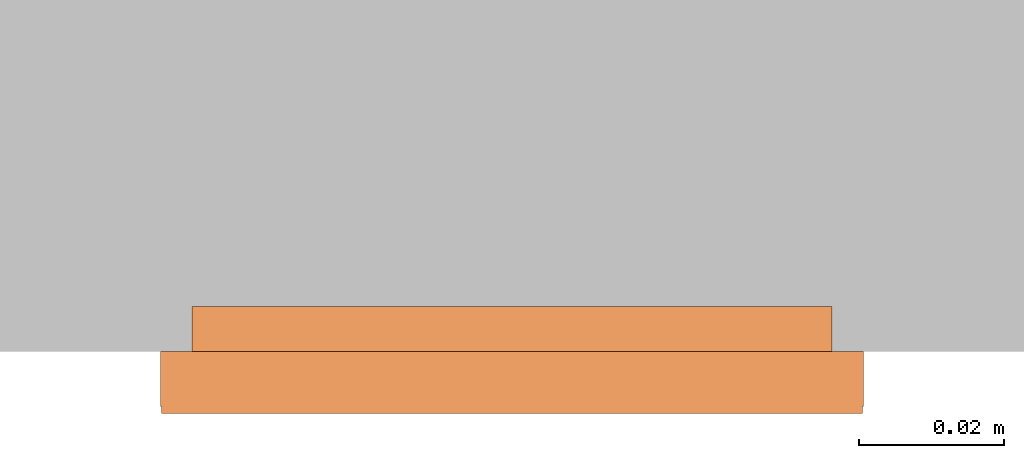
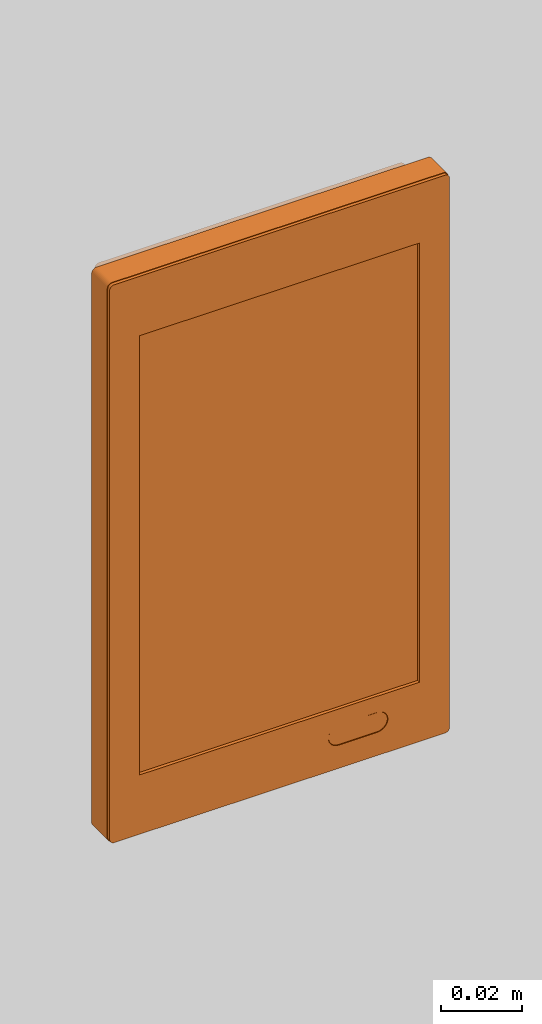
# One storey, part 2 of 2: 1 proxy.
"""IFC2X3 building model written with IfcOpenShell, lengths in metres."""

from ifc_helpers import new_model, entity, si_unit, converted_unit, derived_unit, direction, frame, frame_2d, origin, place, context, subcontext, project, spatial, polyline, circle_curve, parameter, trimmed, segment, composite_curve, outline, extrude, source, transform, mapped, material, material_list, type_object, type_shapes, element, save


model = new_model("IFC2X3")

# Units and contexts
model_context = context("Model", 3, precision=1e-05, world=origin(), true_north=direction((6.12303176911189e-17, 1.0)))
body_context = subcontext(model_context, "Body", "Model", "MODEL_VIEW")
ifc_project = project(units=[si_unit("LENGTHUNIT", "METRE"), si_unit("AREAUNIT", "SQUARE_METRE"), si_unit("VOLUMEUNIT", "CUBIC_METRE"), converted_unit("PLANEANGLEUNIT", "DEGREE", entity("IfcRatioMeasure", 0.0174532925199433), si_unit("PLANEANGLEUNIT", "RADIAN"), dimensions=[0, 0, 0, 0, 0, 0, 0]), si_unit("MASSUNIT", "GRAM", prefix="KILO"), si_unit("TIMEUNIT", "SECOND"), si_unit("FREQUENCYUNIT", "HERTZ"), si_unit("THERMODYNAMICTEMPERATUREUNIT", "DEGREE_CELSIUS"), derived_unit("THERMALTRANSMITTANCEUNIT", [(si_unit("MASSUNIT", "GRAM", prefix="KILO"), 1), (si_unit("THERMODYNAMICTEMPERATUREUNIT", "KELVIN"), -1), (si_unit("TIMEUNIT", "SECOND"), -3)]), derived_unit("VOLUMETRICFLOWRATEUNIT", [(si_unit("LENGTHUNIT", "METRE"), 3), (si_unit("TIMEUNIT", "SECOND"), -1)]), si_unit("ELECTRICCURRENTUNIT", "AMPERE"), si_unit("ELECTRICVOLTAGEUNIT", "VOLT"), si_unit("POWERUNIT", "WATT"), si_unit("FORCEUNIT", "NEWTON", prefix="KILO"), si_unit("ILLUMINANCEUNIT", "LUX"), si_unit("LUMINOUSFLUXUNIT", "LUMEN"), si_unit("LUMINOUSINTENSITYUNIT", "CANDELA"), derived_unit("USERDEFINED", [(si_unit("MASSUNIT", "GRAM", prefix="KILO"), -1), (si_unit("LENGTHUNIT", "METRE"), -2), (si_unit("TIMEUNIT", "SECOND"), 3), (si_unit("LUMINOUSFLUXUNIT", "LUMEN"), 1)]), derived_unit("LINEARVELOCITYUNIT", [(si_unit("LENGTHUNIT", "METRE"), 1), (si_unit("TIMEUNIT", "SECOND"), -1)]), si_unit("PRESSUREUNIT", "PASCAL"), derived_unit("USERDEFINED", [(si_unit("LENGTHUNIT", "METRE"), -2), (si_unit("MASSUNIT", "GRAM", prefix="KILO"), 1), (si_unit("TIMEUNIT", "SECOND"), -2)])], contexts=[model_context])

# Site, building, storey
site_placement = place(None, origin())
site = spatial("IfcSite", under=ifc_project, at=site_placement, CompositionType="ELEMENT")
building_placement = place(site_placement, origin())
building = spatial("IfcBuilding", under=site, at=building_placement, CompositionType="ELEMENT")
storey_placement = place(building_placement, origin())
storey = spatial("IfcBuildingStorey", under=building, at=storey_placement, Name="Ebene 0", CompositionType="ELEMENT", Elevation=0.0)

# Proxy
ifc_material_1 = material(Name="Black")
ifc_material_2 = material(Name="White")
ifc_material_list_1 = material_list([ifc_material_1, ifc_material_2])
ifc_material_list_2 = material_list([ifc_material_1, ifc_material_2])
building_element_proxy_type = type_object("IfcBuildingElementProxyType", PredefinedType="NOTDEFINED", material=ifc_material_list_2)
shared_shape = source(origin(), body_context, "Body", "SweptSolid", [
    extrude(outline(composite_curve([segment(trimmed(circle_curve(frame_2d((0.00547696604971986, 0.0), x_axis=(1.0, 0.0)), 0.0029), [parameter(270.0)], [parameter(89.9999999959255)], True, "PARAMETER"), True, "CONTINUOUS"), segment(polyline([(0.00547696604992609, 0.00289999999982142), (-0.00547696604971984, 0.00290000000060041)]), True, "CONTINUOUS"), segment(trimmed(circle_curve(frame_2d((-0.00547696604992607, 0.0), x_axis=(1.0, 0.0)), 0.00290000000042179), [parameter(89.9999999959255)], [parameter(270.0)], True, "PARAMETER"), True, "CONTINUOUS"), segment(polyline([(-0.00547696604992609, -0.00290000000024318), (0.00547696604971986, -0.00290000000017858)]), True, "CONTINUOUS")], self_intersect=False)), frame((0.0223030339497387, -0.073870001000204, 0.00599999999999813), z_axis=(0.0, 0.0, 1.0), x_axis=(-1.0, 0.0, 0.0)), (0.0, 0.0, 1.0), 0.0025),
    extrude(outline(composite_curve([segment(trimmed(circle_curve(frame_2d((-0.0470000000192189, 0.0825000000256545), x_axis=(1.0, 0.0)), 0.00134999997434544), [parameter(89.9999999999997)], [parameter(180.0)], True, "PARAMETER"), True, "CONTINUOUS"), segment(polyline([(-0.0483499999935644, 0.0825000000256545), (-0.0483499999935644, -0.0825000000256545)]), True, "CONTINUOUS"), segment(trimmed(circle_curve(frame_2d((-0.0470000000192189, -0.0825000000256546), x_axis=(1.0, 0.0)), 0.00134999997434547), [parameter(179.999999999999)], [parameter(270.0)], True, "PARAMETER"), True, "CONTINUOUS"), segment(polyline([(-0.0470000000192189, -0.08385), (0.0470000000063476, -0.08385)]), True, "CONTINUOUS"), segment(trimmed(circle_curve(frame_2d((0.0470000000063476, -0.0824999999999119), x_axis=(1.0, 0.0)), 0.0013500000000881), [parameter(270.0)], [parameter(0.0)], True, "PARAMETER"), True, "CONTINUOUS"), segment(polyline([(0.0483500000064357, -0.0824999999999119), (0.0483500000064357, 0.0824999999999119)]), True, "CONTINUOUS"), segment(trimmed(circle_curve(frame_2d((0.0470000000063476, 0.0824999999999119), x_axis=(1.0, 0.0)), 0.00135000000008807), [parameter(7.12444248647828e-13)], [parameter(90.0000000000001)], True, "PARAMETER"), True, "CONTINUOUS"), segment(polyline([(0.0470000000063476, 0.08385), (-0.0470000000192189, 0.08385)]), True, "CONTINUOUS")], self_intersect=False), holes=[polyline([(-0.0398019999935643, 0.06602), (0.0398020000064357, 0.06602), (0.0398020000064357, -0.06602), (-0.0398019999935643, -0.06602), (-0.0398019999935643, 0.06602)]), composite_curve([segment(trimmed(circle_curve(frame_2d((0.0277800000060816, -0.0738700010003572), x_axis=(-1.0, 0.0)), 0.00300000000042179), [parameter(90.0000000000005)], [parameter(270.0)], True, "PARAMETER"), False, "CONTINUOUS"), segment(polyline([(0.0277800000060816, -0.076870001000779), (0.0168260679064357, -0.076870001)]), True, "CONTINUOUS"), segment(trimmed(circle_curve(frame_2d((0.0168260679064357, -0.073870001), x_axis=(-1.0, 0.0)), 0.003), [parameter(270.0)], [parameter(90.0)], True, "PARAMETER"), False, "CONTINUOUS"), segment(polyline([(0.0168260679064357, -0.070870001), (0.0277800000060816, -0.070870001)]), True, "CONTINUOUS")], self_intersect=False)]), frame((0.0, 0.0, 0.00599999999999813)), (0.0, 0.0, 1.0), 0.00260400720999804),
    extrude(outline(composite_curve([segment(polyline([(-0.0786099000545572, -0.0441531805170125), (0.0786099000545572, -0.0441531805170125)]), True, "CONTINUOUS"), segment(trimmed(circle_curve(frame_2d((0.0786099000545572, -0.0426609562829875), x_axis=(0.0, 1.0)), 0.00149222423402498), [parameter(180.0)], [parameter(270.0)], True, "PARAMETER"), True, "CONTINUOUS"), segment(polyline([(0.0801021242885822, -0.0426609562829875), (0.0801021242885822, 0.0426609562829875)]), True, "CONTINUOUS"), segment(trimmed(circle_curve(frame_2d((0.0786099000545572, 0.0426609562829875), x_axis=(0.0, -1.0)), 0.00149222423402498), [parameter(89.9999999999998)], [parameter(180.0)], True, "PARAMETER"), True, "CONTINUOUS"), segment(polyline([(0.0786099000545572, 0.0441531805170125), (-0.0786099000545572, 0.0441531805170125)]), True, "CONTINUOUS"), segment(trimmed(circle_curve(frame_2d((-0.0786099000545572, 0.0426609562829875), x_axis=(0.0, -1.0)), 0.00149222423402498), [parameter(180.0)], [parameter(270.0)], True, "PARAMETER"), True, "CONTINUOUS"), segment(polyline([(-0.0801021242885822, 0.0426609562829875), (-0.0801021242885822, -0.0426609562829875)]), True, "CONTINUOUS"), segment(trimmed(circle_curve(frame_2d((-0.0786099000545572, -0.0426609562829875), x_axis=(0.0, 1.0)), 0.00149222423402498), [parameter(89.9999999999998)], [parameter(180.0)], True, "PARAMETER"), True, "CONTINUOUS")], self_intersect=False)), frame((0.0, 0.0, -0.00619571867400382), z_axis=(0.0, 0.0, 1.0), x_axis=(0.0, 1.0, 0.0)), (0.0, 0.0, 1.0), 0.00619571867400195),
    extrude(outline(composite_curve([segment(polyline([(-0.0469999999998232, -0.0839999999999829), (0.046999999999824, -0.0839999999999829)]), True, "CONTINUOUS"), segment(trimmed(circle_curve(frame_2d((0.046999999999824, -0.082499999999819), x_axis=(1.0, 0.0)), 0.00150000000016392), [parameter(269.999999999999)], [parameter(359.999999999999)], True, "PARAMETER"), True, "CONTINUOUS"), segment(polyline([(0.0484999999999879, -0.082499999999819), (0.0484999999999871, 0.0824999999998193)]), True, "CONTINUOUS"), segment(trimmed(circle_curve(frame_2d((0.0469999999998232, 0.0824999999998193), x_axis=(1.0, 0.0)), 0.00150000000016392), [parameter(0.0)], [parameter(90.0000000000004)], True, "PARAMETER"), True, "CONTINUOUS"), segment(polyline([(0.0469999999998232, 0.0839999999999832), (-0.046999999999824, 0.0839999999999828)]), True, "CONTINUOUS"), segment(trimmed(circle_curve(frame_2d((-0.046999999999824, 0.0824999999998188), x_axis=(-1.0, 0.0)), 0.00150000000016392), [parameter(269.999999999999)], [parameter(0.0)], True, "PARAMETER"), True, "CONTINUOUS"), segment(polyline([(-0.0484999999999879, 0.0824999999998188), (-0.0484999999999871, -0.0824999999998194)]), True, "CONTINUOUS"), segment(trimmed(circle_curve(frame_2d((-0.0469999999998232, -0.0824999999998194), x_axis=(-1.0, 0.0)), 0.00150000000016392), [parameter(0.0)], [parameter(90.0000000000001)], True, "PARAMETER"), True, "CONTINUOUS")], self_intersect=False)), frame((0.0, 0.0, 0.0), z_axis=(0.0, 0.0, 1.0), x_axis=(-1.0, 0.0, 0.0)), (0.0, 0.0, 1.0), 0.00765400720999807),
])
type_shapes(building_element_proxy_type, [shared_shape])
proxy_placement = place(storey_placement, frame((-6.7192018927039, -2.38240134987377, 1.39505200639602), z_axis=(0.0, -1.0, 0.0), x_axis=(1.0, 0.0, 0.0)))
element("IfcBuildingElementProxy", 1, at=proxy_placement, inside=storey, type_object=building_element_proxy_type, material=ifc_material_list_1, context=body_context, shape_type="MappedRepresentation", body=[
    mapped(shared_shape, transform((0.0, 0.0, 0.0), scale=1.0)),
])

save(model, "model.ifc")
